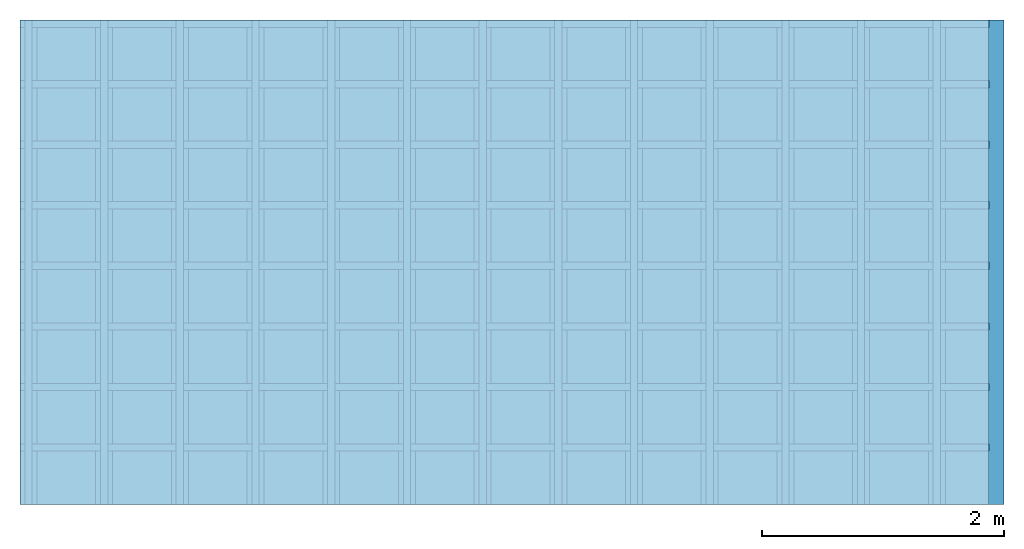
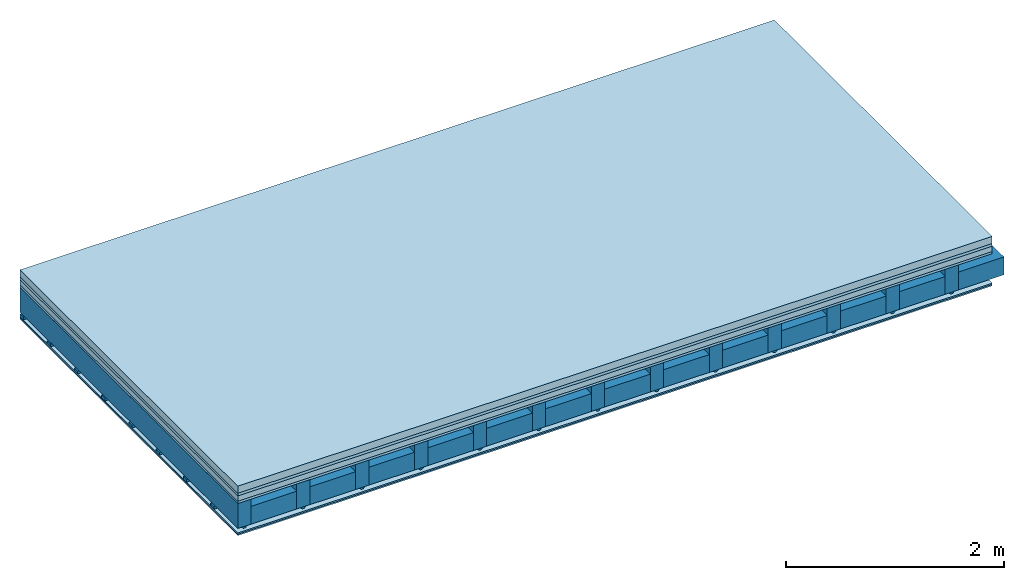
# One storey: 6 plates, 4 members, 1 element without a shape of its own.
"""IFC4 building model written with IfcOpenShell, lengths in metres."""

from ifc_helpers import new_model, si_unit, derived_unit, direction, frame, frame_2d, origin, origin_with_axes, place, context, project, spatial, polyline, rectangle, outline, extrude, material, layer, layer_set, type_object, element, aggregate, save


model = new_model("IFC4")

# Units and contexts
plan_context = context("Plan", 3, precision=1e-05, world=origin(), true_north=direction((0.0, 1.0)))
model_context = context("Model", 3, precision=1e-05, world=origin(), true_north=direction((0.0, 1.0)))
ifc_project = project(units=[si_unit("LENGTHUNIT", "METRE"), derived_unit("SOUNDPRESSUREUNIT", [(si_unit("PRESSUREUNIT", "PASCAL", prefix="MICRO"), 0)]), si_unit("ENERGYUNIT", "JOULE", prefix="MEGA"), si_unit("MASSUNIT", "GRAM", prefix="KILO"), derived_unit("THERMALTRANSMITTANCEUNIT", [(si_unit("POWERUNIT", "WATT"), 1), (si_unit("AREAUNIT", "SQUARE_METRE"), -1), (si_unit("THERMODYNAMICTEMPERATUREUNIT", "KELVIN"), -1)]), derived_unit("AREADENSITYUNIT", [(si_unit("MASSUNIT", "GRAM", prefix="KILO"), 1), (si_unit("AREAUNIT", "SQUARE_METRE"), -1)]), derived_unit("USERDEFINED", [(si_unit("ENERGYUNIT", "JOULE", prefix="MEGA"), 1), (si_unit("AREAUNIT", "SQUARE_METRE"), -1)])], contexts=[plan_context, model_context])

# Site, building, storey
site = spatial("IfcSite", under=ifc_project)
building_placement = place(None, origin())
building = spatial("IfcBuilding", under=site, at=building_placement)
storey_placement = place(building_placement, origin())
storey = spatial("IfcBuildingStorey", under=building, at=storey_placement)

# Slab, members, plates
ifc_material_1 = material(Name="Cement screed", Category="04.006")
ifc_layer_1 = layer(ifc_material_1, 0.08, Name="On-material")
ifc_material_2 = material()
ifc_layer_2 = layer(ifc_material_2, 0.03, Name="Impact sound insulation")
ifc_material_3 = material(Category="03.011")
ifc_layer_3 = layer(ifc_material_3, 0.06, Name="on Supporting structure")
ifc_material_4 = material(Category="07.001")
ifc_layer_4 = layer(ifc_material_4, 0.025, Name="Sub-floor")
ifc_material_5 = material(Name="of the art")
ifc_layer_5 = layer(ifc_material_5, 0.0, Name="Bond")
ifc_layer_6 = layer(None, 0.28, Name="Supporting structure")
ifc_material_6 = material(Name="no composite action")
ifc_layer_7 = layer(ifc_material_6, 0.0, Name="Bond")
ifc_layer_8 = layer(None, 0.02, Name="Coupling")
ifc_layer_9 = layer(None, 0.03, Name="Battens / profiles")
ifc_material_7 = material(Name="Plasterboard type A", Category="03.008")
ifc_layer_10 = layer(ifc_material_7, 0.015, Name="Ceiling covering 1st layer")
ifc_layer_11 = layer(ifc_material_7, 0.015, Name="Ceiling covering layer 2")
ifc_material_8 = material(Name="joints", Category="04.017")
ifc_layer_12 = layer(ifc_material_8, 0.0, Name="Surface / treatment")
ifc_layer_set = layer_set([ifc_layer_1, ifc_layer_2, ifc_layer_3, ifc_layer_4, ifc_layer_5, ifc_layer_6, ifc_layer_7, ifc_layer_8, ifc_layer_9, ifc_layer_10, ifc_layer_11, ifc_layer_12])
slab_type = type_object("IfcSlabType", Name="A0263", PredefinedType="NOTDEFINED", material=ifc_layer_set)
slab_placement = place(None, frame((0.0, 0.0, 0.0), z_axis=(0.0, 0.0, -1.0), x_axis=(1.0, 0.0, 0.0)))
slab = element("IfcSlab", 1, at=slab_placement, inside=storey, type_object=slab_type, material=ifc_layer_set, Name="Slab #1")
ifc_material_9 = material()
member_1_placement = place(slab_placement, origin())
member_1 = element("IfcMember", 2, at=member_1_placement, material=ifc_material_9, Name="Supporting structure", context=plan_context, shape_type="SweptSolid", body=[
    extrude(rectangle(XDim=0.14, YDim=0.28, at=frame_2d((0.07, 0.14), x_axis=(1.0, 0.0))), frame((0.0, 4.0, 0.195), z_axis=(0.0, -1.0, 0.0), x_axis=(1.0, 0.0, 0.0)), (0.0, 0.0, 1.0), 4.0),
    extrude(rectangle(XDim=0.14, YDim=0.28, at=frame_2d((0.07, 0.14), x_axis=(1.0, 0.0))), frame((0.625, 4.0, 0.195), z_axis=(0.0, -1.0, 0.0), x_axis=(1.0, 0.0, 0.0)), (0.0, 0.0, 1.0), 4.0),
    extrude(rectangle(XDim=0.14, YDim=0.28, at=frame_2d((0.07, 0.14), x_axis=(1.0, 0.0))), frame((1.25, 4.0, 0.195), z_axis=(0.0, -1.0, 0.0), x_axis=(1.0, 0.0, 0.0)), (0.0, 0.0, 1.0), 4.0),
    extrude(rectangle(XDim=0.14, YDim=0.28, at=frame_2d((0.07, 0.14), x_axis=(1.0, 0.0))), frame((1.875, 4.0, 0.195), z_axis=(0.0, -1.0, 0.0), x_axis=(1.0, 0.0, 0.0)), (0.0, 0.0, 1.0), 4.0),
    extrude(rectangle(XDim=0.14, YDim=0.28, at=frame_2d((0.07, 0.14), x_axis=(1.0, 0.0))), frame((2.5, 4.0, 0.195), z_axis=(0.0, -1.0, 0.0), x_axis=(1.0, 0.0, 0.0)), (0.0, 0.0, 1.0), 4.0),
    extrude(rectangle(XDim=0.14, YDim=0.28, at=frame_2d((0.07, 0.14), x_axis=(1.0, 0.0))), frame((3.125, 4.0, 0.195), z_axis=(0.0, -1.0, 0.0), x_axis=(1.0, 0.0, 0.0)), (0.0, 0.0, 1.0), 4.0),
    extrude(rectangle(XDim=0.14, YDim=0.28, at=frame_2d((0.07, 0.14), x_axis=(1.0, 0.0))), frame((3.75, 4.0, 0.195), z_axis=(0.0, -1.0, 0.0), x_axis=(1.0, 0.0, 0.0)), (0.0, 0.0, 1.0), 4.0),
    extrude(rectangle(XDim=0.14, YDim=0.28, at=frame_2d((0.07, 0.14), x_axis=(1.0, 0.0))), frame((4.375, 4.0, 0.195), z_axis=(0.0, -1.0, 0.0), x_axis=(1.0, 0.0, 0.0)), (0.0, 0.0, 1.0), 4.0),
    extrude(rectangle(XDim=0.14, YDim=0.28, at=frame_2d((0.07, 0.14), x_axis=(1.0, 0.0))), frame((5.0, 4.0, 0.195), z_axis=(0.0, -1.0, 0.0), x_axis=(1.0, 0.0, 0.0)), (0.0, 0.0, 1.0), 4.0),
    extrude(rectangle(XDim=0.14, YDim=0.28, at=frame_2d((0.07, 0.14), x_axis=(1.0, 0.0))), frame((5.625, 4.0, 0.195), z_axis=(0.0, -1.0, 0.0), x_axis=(1.0, 0.0, 0.0)), (0.0, 0.0, 1.0), 4.0),
    extrude(rectangle(XDim=0.14, YDim=0.28, at=frame_2d((0.07, 0.14), x_axis=(1.0, 0.0))), frame((6.25, 4.0, 0.195), z_axis=(0.0, -1.0, 0.0), x_axis=(1.0, 0.0, 0.0)), (0.0, 0.0, 1.0), 4.0),
    extrude(rectangle(XDim=0.14, YDim=0.28, at=frame_2d((0.07, 0.14), x_axis=(1.0, 0.0))), frame((6.875, 4.0, 0.195), z_axis=(0.0, -1.0, 0.0), x_axis=(1.0, 0.0, 0.0)), (0.0, 0.0, 1.0), 4.0),
    extrude(rectangle(XDim=0.14, YDim=0.28, at=frame_2d((0.07, 0.14), x_axis=(1.0, 0.0))), frame((7.5, 4.0, 0.195), z_axis=(0.0, -1.0, 0.0), x_axis=(1.0, 0.0, 0.0)), (0.0, 0.0, 1.0), 4.0),
])
ifc_material_10 = material()
member_2_placement = place(slab_placement, origin())
member_2 = element("IfcMember", 3, at=member_2_placement, material=ifc_material_10, Name="Cavity", context=plan_context, shape_type="SweptSolid", body=[
    extrude(rectangle(XDim=0.485, YDim=0.2, at=frame_2d((0.2425, 0.1), x_axis=(1.0, 0.0))), frame((0.14, 4.0, 0.275), z_axis=(0.0, -1.0, 0.0), x_axis=(1.0, 0.0, 0.0)), (0.0, 0.0, 1.0), 4.0),
    extrude(rectangle(XDim=0.485, YDim=0.2, at=frame_2d((0.2425, 0.1), x_axis=(1.0, 0.0))), frame((0.765, 4.0, 0.275), z_axis=(0.0, -1.0, 0.0), x_axis=(1.0, 0.0, 0.0)), (0.0, 0.0, 1.0), 4.0),
    extrude(rectangle(XDim=0.485, YDim=0.2, at=frame_2d((0.2425, 0.1), x_axis=(1.0, 0.0))), frame((1.39, 4.0, 0.275), z_axis=(0.0, -1.0, 0.0), x_axis=(1.0, 0.0, 0.0)), (0.0, 0.0, 1.0), 4.0),
    extrude(rectangle(XDim=0.485, YDim=0.2, at=frame_2d((0.2425, 0.1), x_axis=(1.0, 0.0))), frame((2.015, 4.0, 0.275), z_axis=(0.0, -1.0, 0.0), x_axis=(1.0, 0.0, 0.0)), (0.0, 0.0, 1.0), 4.0),
    extrude(rectangle(XDim=0.485, YDim=0.2, at=frame_2d((0.2425, 0.1), x_axis=(1.0, 0.0))), frame((2.64, 4.0, 0.275), z_axis=(0.0, -1.0, 0.0), x_axis=(1.0, 0.0, 0.0)), (0.0, 0.0, 1.0), 4.0),
    extrude(rectangle(XDim=0.485, YDim=0.2, at=frame_2d((0.2425, 0.1), x_axis=(1.0, 0.0))), frame((3.265, 4.0, 0.275), z_axis=(0.0, -1.0, 0.0), x_axis=(1.0, 0.0, 0.0)), (0.0, 0.0, 1.0), 4.0),
    extrude(rectangle(XDim=0.485, YDim=0.2, at=frame_2d((0.2425, 0.1), x_axis=(1.0, 0.0))), frame((3.89, 4.0, 0.275), z_axis=(0.0, -1.0, 0.0), x_axis=(1.0, 0.0, 0.0)), (0.0, 0.0, 1.0), 4.0),
    extrude(rectangle(XDim=0.485, YDim=0.2, at=frame_2d((0.2425, 0.1), x_axis=(1.0, 0.0))), frame((4.515, 4.0, 0.275), z_axis=(0.0, -1.0, 0.0), x_axis=(1.0, 0.0, 0.0)), (0.0, 0.0, 1.0), 4.0),
    extrude(rectangle(XDim=0.485, YDim=0.2, at=frame_2d((0.2425, 0.1), x_axis=(1.0, 0.0))), frame((5.14, 4.0, 0.275), z_axis=(0.0, -1.0, 0.0), x_axis=(1.0, 0.0, 0.0)), (0.0, 0.0, 1.0), 4.0),
    extrude(rectangle(XDim=0.485, YDim=0.2, at=frame_2d((0.2425, 0.1), x_axis=(1.0, 0.0))), frame((5.765, 4.0, 0.275), z_axis=(0.0, -1.0, 0.0), x_axis=(1.0, 0.0, 0.0)), (0.0, 0.0, 1.0), 4.0),
    extrude(rectangle(XDim=0.485, YDim=0.2, at=frame_2d((0.2425, 0.1), x_axis=(1.0, 0.0))), frame((6.39, 4.0, 0.275), z_axis=(0.0, -1.0, 0.0), x_axis=(1.0, 0.0, 0.0)), (0.0, 0.0, 1.0), 4.0),
    extrude(rectangle(XDim=0.485, YDim=0.2, at=frame_2d((0.2425, 0.1), x_axis=(1.0, 0.0))), frame((7.015, 4.0, 0.275), z_axis=(0.0, -1.0, 0.0), x_axis=(1.0, 0.0, 0.0)), (0.0, 0.0, 1.0), 4.0),
    extrude(rectangle(XDim=0.485, YDim=0.2, at=frame_2d((0.2425, 0.1), x_axis=(1.0, 0.0))), frame((7.64, 4.0, 0.275), z_axis=(0.0, -1.0, 0.0), x_axis=(1.0, 0.0, 0.0)), (0.0, 0.0, 1.0), 4.0),
])
ifc_material_11 = material()
member_3_placement = place(slab_placement, origin())
member_3 = element("IfcMember", 4, at=member_3_placement, material=ifc_material_11, Name="Coupling", context=plan_context, shape_type="SweptSolid", body=[
    extrude(outline(polyline([(0.0, 0.0), (0.06, 0.0), (0.04, 0.02), (0.02, 0.02), (0.0, 0.0)])), frame((0.04, 4.0, 0.475), z_axis=(0.0, -1.0, 0.0), x_axis=(1.0, 0.0, 0.0)), (0.0, 0.0, 1.0), 4.0),
    extrude(outline(polyline([(0.0, 0.0), (0.06, 0.0), (0.04, 0.02), (0.02, 0.02), (0.0, 0.0)])), frame((0.665, 4.0, 0.475), z_axis=(0.0, -1.0, 0.0), x_axis=(1.0, 0.0, 0.0)), (0.0, 0.0, 1.0), 4.0),
    extrude(outline(polyline([(0.0, 0.0), (0.06, 0.0), (0.04, 0.02), (0.02, 0.02), (0.0, 0.0)])), frame((1.29, 4.0, 0.475), z_axis=(0.0, -1.0, 0.0), x_axis=(1.0, 0.0, 0.0)), (0.0, 0.0, 1.0), 4.0),
    extrude(outline(polyline([(0.0, 0.0), (0.06, 0.0), (0.04, 0.02), (0.02, 0.02), (0.0, 0.0)])), frame((1.915, 4.0, 0.475), z_axis=(0.0, -1.0, 0.0), x_axis=(1.0, 0.0, 0.0)), (0.0, 0.0, 1.0), 4.0),
    extrude(outline(polyline([(0.0, 0.0), (0.06, 0.0), (0.04, 0.02), (0.02, 0.02), (0.0, 0.0)])), frame((2.54, 4.0, 0.475), z_axis=(0.0, -1.0, 0.0), x_axis=(1.0, 0.0, 0.0)), (0.0, 0.0, 1.0), 4.0),
    extrude(outline(polyline([(0.0, 0.0), (0.06, 0.0), (0.04, 0.02), (0.02, 0.02), (0.0, 0.0)])), frame((3.165, 4.0, 0.475), z_axis=(0.0, -1.0, 0.0), x_axis=(1.0, 0.0, 0.0)), (0.0, 0.0, 1.0), 4.0),
    extrude(outline(polyline([(0.0, 0.0), (0.06, 0.0), (0.04, 0.02), (0.02, 0.02), (0.0, 0.0)])), frame((3.79, 4.0, 0.475), z_axis=(0.0, -1.0, 0.0), x_axis=(1.0, 0.0, 0.0)), (0.0, 0.0, 1.0), 4.0),
    extrude(outline(polyline([(0.0, 0.0), (0.06, 0.0), (0.04, 0.02), (0.02, 0.02), (0.0, 0.0)])), frame((4.415, 4.0, 0.475), z_axis=(0.0, -1.0, 0.0), x_axis=(1.0, 0.0, 0.0)), (0.0, 0.0, 1.0), 4.0),
    extrude(outline(polyline([(0.0, 0.0), (0.06, 0.0), (0.04, 0.02), (0.02, 0.02), (0.0, 0.0)])), frame((5.04, 4.0, 0.475), z_axis=(0.0, -1.0, 0.0), x_axis=(1.0, 0.0, 0.0)), (0.0, 0.0, 1.0), 4.0),
    extrude(outline(polyline([(0.0, 0.0), (0.06, 0.0), (0.04, 0.02), (0.02, 0.02), (0.0, 0.0)])), frame((5.665, 4.0, 0.475), z_axis=(0.0, -1.0, 0.0), x_axis=(1.0, 0.0, 0.0)), (0.0, 0.0, 1.0), 4.0),
    extrude(outline(polyline([(0.0, 0.0), (0.06, 0.0), (0.04, 0.02), (0.02, 0.02), (0.0, 0.0)])), frame((6.29, 4.0, 0.475), z_axis=(0.0, -1.0, 0.0), x_axis=(1.0, 0.0, 0.0)), (0.0, 0.0, 1.0), 4.0),
    extrude(outline(polyline([(0.0, 0.0), (0.06, 0.0), (0.04, 0.02), (0.02, 0.02), (0.0, 0.0)])), frame((6.915, 4.0, 0.475), z_axis=(0.0, -1.0, 0.0), x_axis=(1.0, 0.0, 0.0)), (0.0, 0.0, 1.0), 4.0),
    extrude(outline(polyline([(0.0, 0.0), (0.06, 0.0), (0.04, 0.02), (0.02, 0.02), (0.0, 0.0)])), frame((7.54, 4.0, 0.475), z_axis=(0.0, -1.0, 0.0), x_axis=(1.0, 0.0, 0.0)), (0.0, 0.0, 1.0), 4.0),
])
ifc_material_12 = material()
member_4_placement = place(slab_placement, origin())
member_4 = element("IfcMember", 5, at=member_4_placement, material=ifc_material_12, Name="Battens / profiles", context=plan_context, shape_type="SweptSolid", body=[
    extrude(rectangle(XDim=0.06, YDim=0.03, at=frame_2d((0.03, 0.015), x_axis=(1.0, 0.0))), frame((0.0, 0.0, 0.495), z_axis=(1.0, 0.0, 0.0), x_axis=(0.0, 1.0, 0.0)), (0.0, 0.0, 1.0), 8.0),
    extrude(rectangle(XDim=0.06, YDim=0.03, at=frame_2d((0.03, 0.015), x_axis=(1.0, 0.0))), frame((0.0, 0.5, 0.495), z_axis=(1.0, 0.0, 0.0), x_axis=(0.0, 1.0, 0.0)), (0.0, 0.0, 1.0), 8.0),
    extrude(rectangle(XDim=0.06, YDim=0.03, at=frame_2d((0.03, 0.015), x_axis=(1.0, 0.0))), frame((0.0, 1.0, 0.495), z_axis=(1.0, 0.0, 0.0), x_axis=(0.0, 1.0, 0.0)), (0.0, 0.0, 1.0), 8.0),
    extrude(rectangle(XDim=0.06, YDim=0.03, at=frame_2d((0.03, 0.015), x_axis=(1.0, 0.0))), frame((0.0, 1.5, 0.495), z_axis=(1.0, 0.0, 0.0), x_axis=(0.0, 1.0, 0.0)), (0.0, 0.0, 1.0), 8.0),
    extrude(rectangle(XDim=0.06, YDim=0.03, at=frame_2d((0.03, 0.015), x_axis=(1.0, 0.0))), frame((0.0, 2.0, 0.495), z_axis=(1.0, 0.0, 0.0), x_axis=(0.0, 1.0, 0.0)), (0.0, 0.0, 1.0), 8.0),
    extrude(rectangle(XDim=0.06, YDim=0.03, at=frame_2d((0.03, 0.015), x_axis=(1.0, 0.0))), frame((0.0, 2.5, 0.495), z_axis=(1.0, 0.0, 0.0), x_axis=(0.0, 1.0, 0.0)), (0.0, 0.0, 1.0), 8.0),
    extrude(rectangle(XDim=0.06, YDim=0.03, at=frame_2d((0.03, 0.015), x_axis=(1.0, 0.0))), frame((0.0, 3.0, 0.495), z_axis=(1.0, 0.0, 0.0), x_axis=(0.0, 1.0, 0.0)), (0.0, 0.0, 1.0), 8.0),
    extrude(rectangle(XDim=0.06, YDim=0.03, at=frame_2d((0.03, 0.015), x_axis=(1.0, 0.0))), frame((0.0, 3.5, 0.495), z_axis=(1.0, 0.0, 0.0), x_axis=(0.0, 1.0, 0.0)), (0.0, 0.0, 1.0), 8.0),
])
plate_1_placement = place(slab_placement, origin())
plate_1 = element("IfcPlate", 6, at=plate_1_placement, material=ifc_material_1, Name="On-material", context=plan_context, shape_type="SweptSolid", body=[
    extrude(rectangle(XDim=8.0, YDim=4.0, at=frame_2d((4.0, 2.0), x_axis=(1.0, 0.0))), origin_with_axes(), (0.0, 0.0, 1.0), 0.08),
])
plate_2_placement = place(slab_placement, origin())
plate_2 = element("IfcPlate", 7, at=plate_2_placement, material=ifc_material_2, Name="Impact sound insulation", context=plan_context, shape_type="SweptSolid", body=[
    extrude(rectangle(XDim=8.0, YDim=4.0, at=frame_2d((4.0, 2.0), x_axis=(1.0, 0.0))), frame((0.0, 0.0, 0.08), z_axis=(0.0, 0.0, 1.0), x_axis=(1.0, 0.0, 0.0)), (0.0, 0.0, 1.0), 0.03),
])
plate_3_placement = place(slab_placement, origin())
plate_3 = element("IfcPlate", 8, at=plate_3_placement, material=ifc_material_3, Name="on Supporting structure", context=plan_context, shape_type="SweptSolid", body=[
    extrude(rectangle(XDim=8.0, YDim=4.0, at=frame_2d((4.0, 2.0), x_axis=(1.0, 0.0))), frame((0.0, 0.0, 0.11), z_axis=(0.0, 0.0, 1.0), x_axis=(1.0, 0.0, 0.0)), (0.0, 0.0, 1.0), 0.06),
])
plate_4_placement = place(slab_placement, origin())
plate_4 = element("IfcPlate", 9, at=plate_4_placement, material=ifc_material_4, Name="Sub-floor", context=plan_context, shape_type="SweptSolid", body=[
    extrude(rectangle(XDim=8.0, YDim=4.0, at=frame_2d((4.0, 2.0), x_axis=(1.0, 0.0))), frame((0.0, 0.0, 0.17), z_axis=(0.0, 0.0, 1.0), x_axis=(1.0, 0.0, 0.0)), (0.0, 0.0, 1.0), 0.025),
])
plate_5_placement = place(slab_placement, origin())
plate_5 = element("IfcPlate", 10, at=plate_5_placement, material=ifc_material_7, Name="Ceiling covering 1st layer", context=plan_context, shape_type="SweptSolid", body=[
    extrude(rectangle(XDim=8.0, YDim=4.0, at=frame_2d((4.0, 2.0), x_axis=(1.0, 0.0))), frame((0.0, 0.0, 0.525), z_axis=(0.0, 0.0, 1.0), x_axis=(1.0, 0.0, 0.0)), (0.0, 0.0, 1.0), 0.015),
])
plate_6_placement = place(slab_placement, origin())
plate_6 = element("IfcPlate", 11, at=plate_6_placement, material=ifc_material_7, Name="Ceiling covering layer 2", context=plan_context, shape_type="SweptSolid", body=[
    extrude(rectangle(XDim=8.0, YDim=4.0, at=frame_2d((4.0, 2.0), x_axis=(1.0, 0.0))), frame((0.0, 0.0, 0.54), z_axis=(0.0, 0.0, 1.0), x_axis=(1.0, 0.0, 0.0)), (0.0, 0.0, 1.0), 0.015),
])
aggregate(slab, [plate_1, plate_2, plate_3, plate_4, member_1, member_2, member_3, member_4, plate_5, plate_6])

save(model, "model.ifc")
